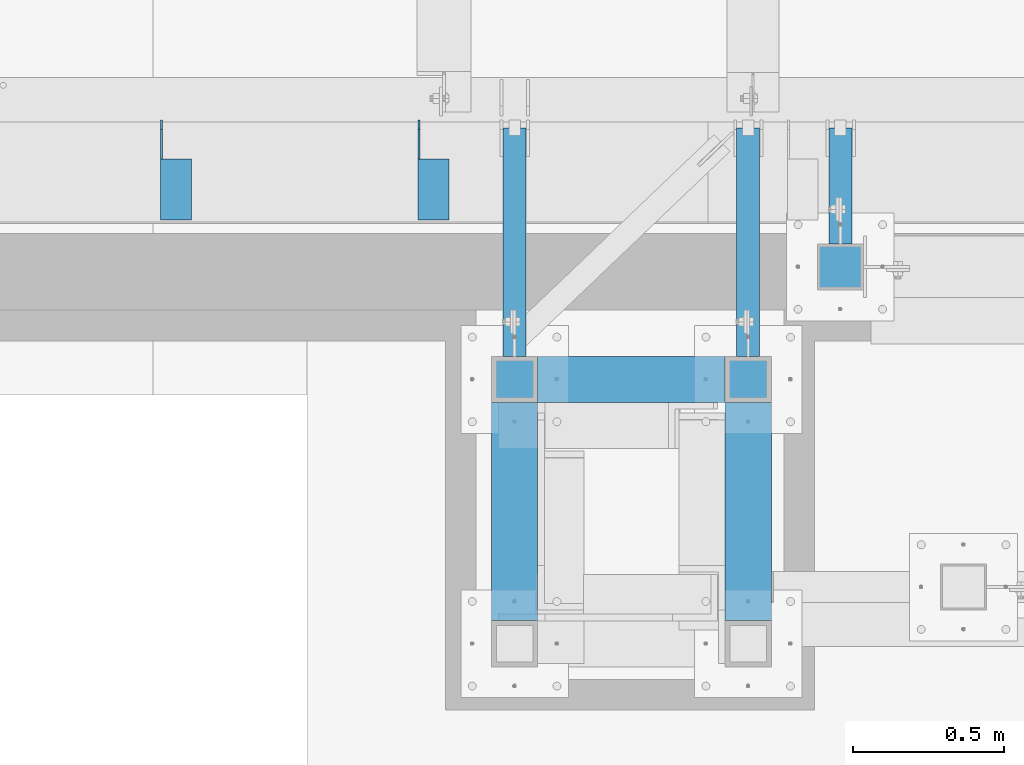
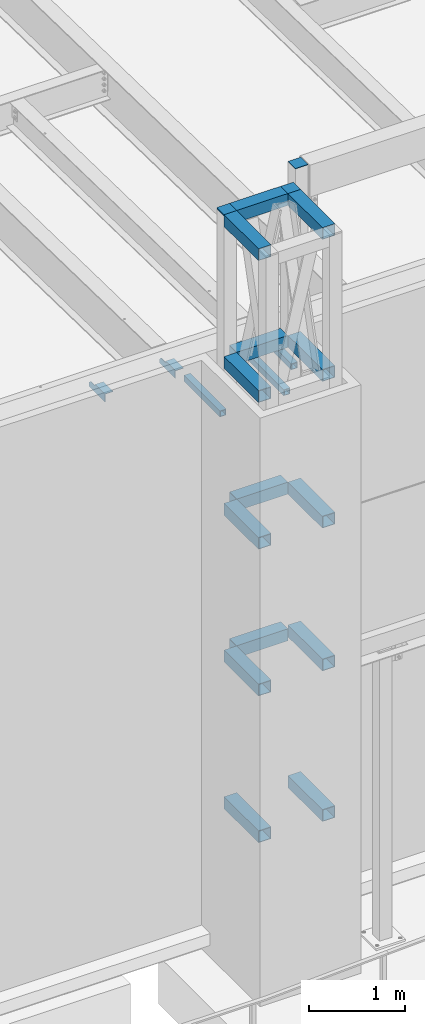
# One storey, part 1180 of 1763: 22 beams, 6 elements without a shape of their own.
"""IFC2X3 building model written with IfcOpenShell, lengths in millimetres."""

from ifc_helpers import new_model, si_unit, frame, origin_with_axes, place, context, subcontext, project, spatial, faceted_brep, material, type_object, element, aggregate, save


model = new_model("IFC2X3")

# Units and contexts
model_context = context("Model", 3, precision=1e-05, world=origin_with_axes())
body_context = subcontext(model_context, "Body", "Model", "MODEL_VIEW")
ifc_project = project(units=[si_unit("LENGTHUNIT", "METRE", prefix="MILLI"), si_unit("AREAUNIT", "SQUARE_METRE"), si_unit("VOLUMEUNIT", "CUBIC_METRE"), si_unit("MASSUNIT", "GRAM", prefix="KILO"), si_unit("TIMEUNIT", "SECOND"), si_unit("PLANEANGLEUNIT", "RADIAN"), si_unit("SOLIDANGLEUNIT", "STERADIAN"), si_unit("THERMODYNAMICTEMPERATUREUNIT", "DEGREE_CELSIUS"), si_unit("LUMINOUSINTENSITYUNIT", "LUMEN")], contexts=[model_context])

# Site, building, storey
site_placement = place(None, origin_with_axes())
site = spatial("IfcSite", under=ifc_project, at=site_placement, CompositionType="ELEMENT")
building_placement = place(site_placement, origin_with_axes())
building = spatial("IfcBuilding", under=site, at=building_placement, Name="Undefined", CompositionType="ELEMENT")
storey_placement = place(building_placement, origin_with_axes())
storey = spatial("IfcBuildingStorey", under=building, at=storey_placement, Name="Undefined", CompositionType="ELEMENT", Elevation=0.0)

# Assembly, beams
assembly_1_placement = place(storey_placement, origin_with_axes())
assembly_1 = element("IfcElementAssembly", 1, at=assembly_1_placement, inside=storey, Name="BEAM", AssemblyPlace="NOTDEFINED", PredefinedType="RIGID_FRAME")
ifc_material_1 = material(Name="STEEL/A36")
beam_type_1 = type_object("IfcBeamType", Name="L4X4X1/4", PredefinedType="NOTDEFINED")
beam_1_placement = place(assembly_1_placement, frame((-70345.6055562792, -13723.1435701429, 12153.8999999999), z_axis=(0.0, 0.0, -1.0), x_axis=(0.0, -1.0, 0.0)))
beam_1 = element("IfcBeam", 2, at=beam_1_placement, type_object=beam_type_1, material=ifc_material_1, Name="BRACE", ObjectType="L4X4X1/4", context=body_context, shape_type="Brep", body=[
    faceted_brep([(127.793748474227, 44.4499999999971, -31.7500007627295), (127.793748474227, 50.8000000000029, -31.7500007627295), (127.793748474225, 50.8000000000029, -50.7999999999993), (127.793748474225, -50.8000000000029, -50.7999999999993), (127.793748474225, -50.8000000000029, -44.4500000000007), (127.793748474225, 44.4499999999971, -44.4500000000007), (31.7499999999673, 44.4499999999971, -31.7500001906901), (31.7499999999673, 50.8000000000029, -31.7500007627295), (-1.81898940354586e-10, 44.4500000000371, 50.7999999999374), (-1.96450855582952e-10, 50.8000000000393, 50.7999999999374), (0.0, 50.8000000000029, -1.90690116141923e-07), (0.0, 44.4499999999971, -1.90690116141923e-07), (329.406260681253, 44.4499999999971, 50.7999999999993), (329.406260681253, 50.8000000000029, 50.7999999999993), (329.406260681253, 44.4499999999971, -44.4500000000007), (329.406260681253, -50.8000000000029, -44.4500000000007), (329.406260681253, -50.8000000000029, -50.7999999999993), (329.406260681253, 50.8000000000029, -50.7999999999993)], [[[0, 1, 2, 3, 4, 5]], [[1, 0, 6, 7]], [[8, 9, 10, 11]], [[9, 8, 12, 13]], [[12, 14, 15, 16, 17, 13]], [[15, 14, 5, 4]], [[16, 15, 4, 3]], [[17, 16, 3, 2]], [[9, 13, 17, 2, 1, 7, 10]], [[6, 11, 10, 7]], [[0, 5, 14, 12, 8, 11, 6]]]),
])
beam_2_placement = place(assembly_1_placement, frame((-71196.5055562792, -13723.1435701429, 12153.8999999998), z_axis=(0.0, 0.0, -1.0), x_axis=(0.0, -1.0, 0.0)))
beam_2 = element("IfcBeam", 3, at=beam_2_placement, type_object=beam_type_1, material=ifc_material_1, Name="BRACE", ObjectType="L4X4X1/4", context=body_context, shape_type="Brep", body=[
    faceted_brep([(127.793748474227, 44.4499999999971, -31.7500007627295), (127.793748474227, 50.8000000000029, -31.7500007627295), (127.793748474225, 50.8000000000029, -50.7999999999993), (127.793748474225, -50.8000000000029, -50.7999999999993), (127.793748474225, -50.8000000000029, -44.4500000000007), (127.793748474225, 44.4499999999971, -44.4500000000007), (31.7499999999673, 44.4499999999971, -31.7500001906901), (31.7499999999673, 50.8000000000029, -31.7500007627295), (-1.81898940354586e-10, 44.4500000000371, 50.7999999999374), (-1.96450855582952e-10, 50.8000000000393, 50.7999999999374), (0.0, 50.8000000000029, -1.90690116141923e-07), (0.0, 44.4499999999971, -1.90690116141923e-07), (329.406260681253, 44.4499999999971, 50.7999999999993), (329.406260681253, 50.8000000000029, 50.7999999999993), (329.406260681253, 44.4499999999971, -44.4500000000007), (329.406260681253, -50.8000000000029, -44.4500000000007), (329.406260681253, -50.8000000000029, -50.7999999999993), (329.406260681253, 50.8000000000029, -50.7999999999993)], [[[0, 1, 2, 3, 4, 5]], [[1, 0, 6, 7]], [[8, 9, 10, 11]], [[9, 8, 12, 13]], [[12, 14, 15, 16, 17, 13]], [[15, 14, 5, 4]], [[16, 15, 4, 3]], [[17, 16, 3, 2]], [[9, 13, 17, 2, 1, 7, 10]], [[6, 11, 10, 7]], [[0, 5, 14, 12, 8, 11, 6]]]),
])
aggregate(assembly_1, [beam_1, beam_2])

# Assembly, beam
assembly_2_placement = place(storey_placement, origin_with_axes())
assembly_2 = element("IfcElementAssembly", 4, at=assembly_2_placement, inside=storey, Name="BEAM", AssemblyPlace="NOTDEFINED", PredefinedType="RIGID_FRAME")
ifc_material_2 = material()
beam_type_2 = type_object("IfcBeamType", Name="HSS3X3X1/4", PredefinedType="NOTDEFINED")
beam_3_placement = place(assembly_2_placement, frame((-69002.1577158888, -14131.9264769908, 11825.2875), z_axis=(0.0, 0.0, 1.0), x_axis=(0.0, 1.0, 0.0)))
beam_3 = element("IfcBeam", 5, at=beam_3_placement, type_object=beam_type_2, material=ifc_material_2, Name="BEAM", ObjectType="HSS3X3X1/4", context=body_context, shape_type="Brep", body=[
    faceted_brep([(0.0, 31.75, -31.75), (0.0, -31.75, -31.75), (383.382908373733, -31.75, -31.75), (383.382908373733, 31.75, -31.75), (0.0, -31.75, 31.75), (383.382908373733, -31.75, 31.75), (0.0, 31.75, 31.75), (383.382908373733, 31.75, 31.75), (0.0, 38.0999999999985, -38.1000000000004), (0.0, 38.0999999999985, 38.1000000000004), (383.382908373733, 38.0999999999985, 38.1000000000004), (383.382908373733, 38.0999999999985, -38.1000000000004), (0.0, -38.0999999999985, 38.1000000000004), (383.382908373733, -38.0999999999985, 38.1000000000004), (0.0, -38.0999999999985, -38.1000000000004), (383.382908373733, -38.0999999999985, -38.1000000000004)], [[[0, 1, 2, 3]], [[1, 4, 5, 2]], [[4, 6, 7, 5]], [[6, 0, 3, 7]], [[8, 9, 10, 11]], [[9, 12, 13, 10]], [[12, 14, 15, 13]], [[14, 8, 11, 15]], [[13, 15, 11, 10], [5, 7, 3, 2]], [[14, 12, 9, 8], [6, 4, 1, 0]]]),
])
aggregate(assembly_2, [beam_3])

assembly_3_placement = place(storey_placement, origin_with_axes())
assembly_3 = element("IfcElementAssembly", 6, at=assembly_3_placement, inside=storey, Name="BEAM", AssemblyPlace="NOTDEFINED", PredefinedType="RIGID_FRAME")
beam_4_placement = place(assembly_3_placement, frame((-69306.51188459, -14503.3992675181, 11825.2875), z_axis=(0.0, 0.0, 1.0), x_axis=(0.0, 1.0, 0.0)))
beam_4 = element("IfcBeam", 7, at=beam_4_placement, type_object=beam_type_2, material=ifc_material_2, Name="BEAM", ObjectType="HSS3X3X1/4", context=body_context, shape_type="Brep", body=[
    faceted_brep([(0.0, 31.75, -31.75), (0.0, -31.75, -31.75), (754.855698901074, -31.75, -31.75), (754.855698901074, 31.75, -31.75), (0.0, -31.75, 31.75), (754.855698901074, -31.75, 31.75), (0.0, 31.75, 31.75), (754.855698901074, 31.75, 31.75), (0.0, 38.0999999999985, -38.1000000000004), (0.0, 38.0999999999985, 38.1000000000004), (754.855698901074, 38.1000000000058, 38.1000000000004), (754.855698901074, 38.1000000000058, -38.1000000000004), (0.0, -38.0999999999985, 38.1000000000004), (754.855698901074, -38.1000000000058, 38.1000000000004), (0.0, -38.0999999999985, -38.1000000000004), (754.855698901074, -38.1000000000058, -38.1000000000004)], [[[0, 1, 2, 3]], [[1, 4, 5, 2]], [[4, 6, 7, 5]], [[6, 0, 3, 7]], [[8, 9, 10, 11]], [[9, 12, 13, 10]], [[12, 14, 15, 13]], [[14, 8, 11, 15]], [[13, 15, 11, 10], [5, 7, 3, 2]], [[14, 12, 9, 8], [6, 4, 1, 0]]]),
])
aggregate(assembly_3, [beam_4])

assembly_4_placement = place(storey_placement, origin_with_axes())
assembly_4 = element("IfcElementAssembly", 8, at=assembly_4_placement, inside=storey, Name="BEAM", AssemblyPlace="NOTDEFINED", PredefinedType="RIGID_FRAME")
beam_5_placement = place(assembly_4_placement, frame((-70078.03688459, -14503.3992675181, 11825.2875), z_axis=(0.0, 0.0, 1.0), x_axis=(0.0, 1.0, 0.0)))
beam_5 = element("IfcBeam", 9, at=beam_5_placement, type_object=beam_type_2, material=ifc_material_2, Name="BEAM", ObjectType="HSS3X3X1/4", context=body_context, shape_type="Brep", body=[
    faceted_brep([(0.0, 31.75, -31.75), (0.0, -31.75, -31.75), (754.855698901074, -31.75, -31.75), (754.855698901074, 31.75, -31.75), (0.0, -31.75, 31.75), (754.855698901074, -31.75, 31.75), (0.0, 31.75, 31.75), (754.855698901074, 31.75, 31.75), (0.0, 38.0999999999985, -38.1000000000004), (0.0, 38.0999999999985, 38.1000000000004), (754.855698901074, 38.1000000000058, 38.1000000000004), (754.855698901074, 38.1000000000058, -38.1000000000004), (0.0, -38.0999999999985, 38.1000000000004), (754.855698901074, -38.1000000000058, 38.1000000000004), (0.0, -38.0999999999985, -38.1000000000004), (754.855698901074, -38.1000000000058, -38.1000000000004)], [[[0, 1, 2, 3]], [[1, 4, 5, 2]], [[4, 6, 7, 5]], [[6, 0, 3, 7]], [[8, 9, 10, 11]], [[9, 12, 13, 10]], [[12, 14, 15, 13]], [[14, 8, 11, 15]], [[13, 15, 11, 10], [5, 7, 3, 2]], [[14, 12, 9, 8], [6, 4, 1, 0]]]),
])
aggregate(assembly_4, [beam_5])

# Assembly, beams
assembly_5_placement = place(storey_placement, origin_with_axes())
assembly_5 = element("IfcElementAssembly", 10, at=assembly_5_placement, inside=storey, Name="FRAME", AssemblyPlace="NOTDEFINED", PredefinedType="RIGID_FRAME")
beam_type_3 = type_object("IfcBeamType", PredefinedType="NOTDEFINED")
beam_6_placement = place(assembly_5_placement, frame((-70078.03688459, -14655.7992675181, 14468.475), z_axis=(1.0, 0.0, 0.0), x_axis=(0.0, 1.0, 0.0)))
beam_6 = element("IfcBeam", 11, at=beam_6_placement, type_object=beam_type_3, material=ifc_material_1, Name="PLATE", context=body_context, shape_type="Brep", body=[
    faceted_brep([(0.0, 9.52499999999964, -76.1999999999971), (0.0, 9.52499999999964, 76.1999999999971), (152.400000000001, 9.52499999999964, 76.1999999999971), (152.400000000001, 9.52499999999964, -76.1999999999971), (0.0, -9.52499999999964, 76.1999999999971), (152.400000000001, -9.52499999999964, 76.1999999999971), (0.0, -9.52499999999964, -76.1999999999971), (152.400000000001, -9.52499999999964, -76.1999999999971)], [[[0, 1, 2, 3]], [[1, 4, 5, 2]], [[4, 6, 7, 5]], [[6, 0, 3, 7]], [[5, 7, 3, 2]], [[6, 4, 1, 0]]]),
])
beam_7_placement = place(assembly_5_placement, frame((-69306.5116892775, -14655.7992675181, 14468.475), z_axis=(1.0, 0.0, 0.0), x_axis=(0.0, 1.0, 0.0)))
beam_7 = element("IfcBeam", 12, at=beam_7_placement, type_object=beam_type_3, material=ifc_material_1, Name="PLATE", context=body_context, shape_type="Brep", body=[
    faceted_brep([(0.0, 9.52499999999964, -76.1999999999971), (0.0, 9.52499999999964, 76.1999999999971), (152.400000000001, 9.52499999999964, 76.1999999999971), (152.400000000001, 9.52499999999964, -76.1999999999971), (0.0, -9.52499999999964, 76.1999999999971), (152.400000000001, -9.52499999999964, 76.1999999999971), (0.0, -9.52499999999964, -76.1999999999971), (152.400000000001, -9.52499999999964, -76.1999999999971)], [[[0, 1, 2, 3]], [[1, 4, 5, 2]], [[4, 6, 7, 5]], [[6, 0, 3, 7]], [[5, 7, 3, 2]], [[6, 4, 1, 0]]]),
])
beam_type_4 = type_object("IfcBeamType", Name="HSS6X6X1/4", PredefinedType="NOTDEFINED")
beam_8_placement = place(assembly_5_placement, frame((-69306.5116892775, -15452.7242675181, 6966.74375), z_axis=(0.0, 0.0, 1.0), x_axis=(0.0, 1.0, 0.0)))
beam_8 = element("IfcBeam", 13, at=beam_8_placement, type_object=beam_type_4, material=ifc_material_2, Name="BEAM", ObjectType="HSS6X6X1/4", context=body_context, shape_type="Brep", body=[
    faceted_brep([(76.2000000000007, 69.8500000000058, -69.8500000000004), (76.2000000000007, -69.8500000000058, -69.8500000000004), (796.924999999999, -69.8500000000058, -69.8500000000004), (796.924999999999, 69.8500000000058, -69.8500000000004), (76.2000000000007, -69.8500000000058, 69.8500000000004), (796.924999999999, -69.8500000000058, 69.8500000000004), (76.2000000000007, 69.8500000000058, 69.8500000000004), (796.924999999999, 69.8500000000058, 69.8500000000004), (76.1999511718459, 76.2000000000007, -76.2000000000007), (76.1999511718459, 76.2000000000007, 76.2000000000007), (796.924999999999, 76.1999999999971, 76.1999999999998), (796.924999999999, 76.1999999999971, -76.1999999999998), (76.1999511718459, -76.2000000000007, 76.2000000000007), (796.924999999999, -76.1999999999971, 76.1999999999998), (76.1999511718459, -76.2000000000007, -76.2000000000007), (796.924999999999, -76.1999999999971, -76.1999999999998)], [[[0, 1, 2, 3]], [[1, 4, 5, 2]], [[4, 6, 7, 5]], [[6, 0, 3, 7]], [[8, 9, 10, 11]], [[9, 12, 13, 10]], [[12, 14, 15, 13]], [[14, 8, 11, 15]], [[13, 15, 11, 10], [5, 7, 3, 2]], [[14, 12, 9, 8], [6, 4, 1, 0]]]),
])
beam_9_placement = place(assembly_5_placement, frame((-70078.0366892775, -15452.7242675181, 6966.74375), z_axis=(0.0, 0.0, 1.0), x_axis=(0.0, 1.0, 0.0)))
beam_9 = element("IfcBeam", 14, at=beam_9_placement, type_object=beam_type_4, material=ifc_material_2, Name="BEAM", ObjectType="HSS6X6X1/4", context=body_context, shape_type="Brep", body=[
    faceted_brep([(76.2000000000007, 69.8500000000058, -69.8500000000004), (76.2000000000007, -69.8500000000058, -69.8500000000004), (796.924999999999, -69.8500000000058, -69.8500000000004), (796.924999999999, 69.8500000000058, -69.8500000000004), (76.2000000000007, -69.8500000000058, 69.8500000000004), (796.924999999999, -69.8500000000058, 69.8500000000004), (76.2000000000007, 69.8500000000058, 69.8500000000004), (796.924999999999, 69.8500000000058, 69.8500000000004), (76.1999511718459, 76.2000000000007, -76.2000000000007), (76.1999511718459, 76.2000000000007, 76.2000000000007), (796.924999999999, 76.1999999999971, 76.1999999999998), (796.924999999999, 76.1999999999971, -76.1999999999998), (76.1999511718459, -76.2000000000007, 76.2000000000007), (796.924999999999, -76.1999999999971, 76.1999999999998), (76.1999511718459, -76.2000000000007, -76.2000000000007), (796.924999999999, -76.1999999999971, -76.1999999999998)], [[[0, 1, 2, 3]], [[1, 4, 5, 2]], [[4, 6, 7, 5]], [[6, 0, 3, 7]], [[8, 9, 10, 11]], [[9, 12, 13, 10]], [[12, 14, 15, 13]], [[14, 8, 11, 15]], [[13, 15, 11, 10], [5, 7, 3, 2]], [[14, 12, 9, 8], [6, 4, 1, 0]]]),
])
beam_10_placement = place(assembly_5_placement, frame((-70078.0366892775, -14579.5992675181, 8840.7875), z_axis=(0.0, 0.0, 1.0), x_axis=(1.0, 0.0, 0.0)))
beam_10 = element("IfcBeam", 15, at=beam_10_placement, type_object=beam_type_4, material=ifc_material_2, Name="BEAM", ObjectType="HSS6X6X1/4", context=body_context, shape_type="Brep", body=[
    faceted_brep([(76.1998046874942, 69.8500000000004, -69.8500000000004), (76.1998046874942, -69.8500000000004, -69.8500000000004), (695.325000000012, -69.8500000000004, -69.8500000000004), (695.325000000012, 69.8500000000004, -69.8500000000004), (76.1998046874942, -69.8500000000004, 69.8500000000004), (695.325000000012, -69.8500000000004, 69.8500000000004), (76.1998046874942, 69.8500000000004, 69.8500000000004), (695.325000000012, 69.8500000000004, 69.8500000000004), (76.1998535156017, 76.2000000000007, -76.1999999999998), (76.1998535156017, 76.2000000000007, 76.1999999999998), (695.325048828119, 76.2000000000007, 76.1999999999998), (695.325048828119, 76.2000000000007, -76.1999999999998), (76.1998535156017, -76.2000000000007, 76.1999999999998), (695.325048828119, -76.2000000000007, 76.1999999999998), (76.1998535156017, -76.2000000000007, -76.1999999999998), (695.325048828119, -76.2000000000007, -76.1999999999998)], [[[0, 1, 2, 3]], [[1, 4, 5, 2]], [[4, 6, 7, 5]], [[6, 0, 3, 7]], [[8, 9, 10, 11]], [[9, 12, 13, 10]], [[12, 14, 15, 13]], [[14, 8, 11, 15]], [[13, 15, 11, 10], [5, 7, 3, 2]], [[14, 12, 9, 8], [6, 4, 1, 0]]]),
])
beam_11_placement = place(assembly_5_placement, frame((-70078.0366892775, -15452.7242675181, 8840.7875), z_axis=(0.0, 0.0, 1.0), x_axis=(0.0, 1.0, 0.0)))
beam_11 = element("IfcBeam", 16, at=beam_11_placement, type_object=beam_type_4, material=ifc_material_2, Name="BEAM", ObjectType="HSS6X6X1/4", context=body_context, shape_type="Brep", body=[
    faceted_brep([(76.2000000000007, 69.8500000000058, -69.8500000000004), (76.2000000000007, -69.8500000000058, -69.8500000000004), (796.924999999999, -69.8500000000058, -69.8500000000004), (796.924999999999, 69.8500000000058, -69.8500000000004), (76.2000000000007, -69.8500000000058, 69.8500000000004), (796.924999999999, -69.8500000000058, 69.8500000000004), (76.2000000000007, 69.8500000000058, 69.8500000000004), (796.924999999999, 69.8500000000058, 69.8500000000004), (76.1999511718459, 76.2000000000007, -76.2000000000007), (76.1999511718459, 76.2000000000007, 76.2000000000007), (796.924999999999, 76.1999999999971, 76.1999999999998), (796.924999999999, 76.1999999999971, -76.1999999999998), (76.1999511718459, -76.2000000000007, 76.2000000000007), (796.924999999999, -76.1999999999971, 76.1999999999998), (76.1999511718459, -76.2000000000007, -76.2000000000007), (796.924999999999, -76.1999999999971, -76.1999999999998)], [[[0, 1, 2, 3]], [[1, 4, 5, 2]], [[4, 6, 7, 5]], [[6, 0, 3, 7]], [[8, 9, 10, 11]], [[9, 12, 13, 10]], [[12, 14, 15, 13]], [[14, 8, 11, 15]], [[13, 15, 11, 10], [5, 7, 3, 2]], [[14, 12, 9, 8], [6, 4, 1, 0]]]),
])
beam_12_placement = place(assembly_5_placement, frame((-70078.0366892775, -14579.5992675181, 10714.83125), z_axis=(0.0, 0.0, 1.0), x_axis=(1.0, 0.0, 0.0)))
beam_12 = element("IfcBeam", 17, at=beam_12_placement, type_object=beam_type_4, material=ifc_material_2, Name="BEAM", ObjectType="HSS6X6X1/4", context=body_context, shape_type="Brep", body=[
    faceted_brep([(76.1998046874942, 69.8500000000004, -69.8500000000004), (76.1998046874942, -69.8500000000004, -69.8500000000004), (695.325000000012, -69.8500000000004, -69.8500000000004), (695.325000000012, 69.8500000000004, -69.8500000000004), (76.1998046874942, -69.8500000000004, 69.8500000000004), (695.325000000012, -69.8500000000004, 69.8500000000004), (76.1998046874942, 69.8500000000004, 69.8500000000004), (695.325000000012, 69.8500000000004, 69.8500000000004), (76.1998535156017, 76.2000000000007, -76.1999999999998), (76.1998535156017, 76.2000000000007, 76.1999999999998), (695.325048828119, 76.2000000000007, 76.1999999999998), (695.325048828119, 76.2000000000007, -76.1999999999998), (76.1998535156017, -76.2000000000007, 76.1999999999998), (695.325048828119, -76.2000000000007, 76.1999999999998), (76.1998535156017, -76.2000000000007, -76.1999999999998), (695.325048828119, -76.2000000000007, -76.1999999999998)], [[[0, 1, 2, 3]], [[1, 4, 5, 2]], [[4, 6, 7, 5]], [[6, 0, 3, 7]], [[8, 9, 10, 11]], [[9, 12, 13, 10]], [[12, 14, 15, 13]], [[14, 8, 11, 15]], [[13, 15, 11, 10], [5, 7, 3, 2]], [[14, 12, 9, 8], [6, 4, 1, 0]]]),
])
beam_13_placement = place(assembly_5_placement, frame((-69306.5116892775, -15452.7242675181, 10714.83125), z_axis=(0.0, 0.0, 1.0), x_axis=(0.0, 1.0, 0.0)))
beam_13 = element("IfcBeam", 18, at=beam_13_placement, type_object=beam_type_4, material=ifc_material_2, Name="BEAM", ObjectType="HSS6X6X1/4", context=body_context, shape_type="Brep", body=[
    faceted_brep([(76.2000000000007, 69.8500000000058, -69.8500000000004), (76.2000000000007, -69.8500000000058, -69.8500000000004), (796.924999999999, -69.8500000000058, -69.8500000000004), (796.924999999999, 69.8500000000058, -69.8500000000004), (76.2000000000007, -69.8500000000058, 69.8500000000004), (796.924999999999, -69.8500000000058, 69.8500000000004), (76.2000000000007, 69.8500000000058, 69.8500000000004), (796.924999999999, 69.8500000000058, 69.8500000000004), (76.1999511718459, 76.2000000000007, -76.2000000000007), (76.1999511718459, 76.2000000000007, 76.2000000000007), (796.924999999999, 76.1999999999971, 76.1999999999998), (796.924999999999, 76.1999999999971, -76.1999999999998), (76.1999511718459, -76.2000000000007, 76.2000000000007), (796.924999999999, -76.1999999999971, 76.1999999999998), (76.1999511718459, -76.2000000000007, -76.2000000000007), (796.924999999999, -76.1999999999971, -76.1999999999998)], [[[0, 1, 2, 3]], [[1, 4, 5, 2]], [[4, 6, 7, 5]], [[6, 0, 3, 7]], [[8, 9, 10, 11]], [[9, 12, 13, 10]], [[12, 14, 15, 13]], [[14, 8, 11, 15]], [[13, 15, 11, 10], [5, 7, 3, 2]], [[14, 12, 9, 8], [6, 4, 1, 0]]]),
])
beam_14_placement = place(assembly_5_placement, frame((-70078.0366892775, -15452.7242675181, 10714.83125), z_axis=(0.0, 0.0, 1.0), x_axis=(0.0, 1.0, 0.0)))
beam_14 = element("IfcBeam", 19, at=beam_14_placement, type_object=beam_type_4, material=ifc_material_2, Name="BEAM", ObjectType="HSS6X6X1/4", context=body_context, shape_type="Brep", body=[
    faceted_brep([(76.2000000000007, 69.8500000000058, -69.8500000000004), (76.2000000000007, -69.8500000000058, -69.8500000000004), (796.924999999999, -69.8500000000058, -69.8500000000004), (796.924999999999, 69.8500000000058, -69.8500000000004), (76.2000000000007, -69.8500000000058, 69.8500000000004), (796.924999999999, -69.8500000000058, 69.8500000000004), (76.2000000000007, 69.8500000000058, 69.8500000000004), (796.924999999999, 69.8500000000058, 69.8500000000004), (76.1999511718459, 76.2000000000007, -76.2000000000007), (76.1999511718459, 76.2000000000007, 76.2000000000007), (796.924999999999, 76.1999999999971, 76.1999999999998), (796.924999999999, 76.1999999999971, -76.1999999999998), (76.1999511718459, -76.2000000000007, 76.2000000000007), (796.924999999999, -76.1999999999971, 76.1999999999998), (76.1999511718459, -76.2000000000007, -76.2000000000007), (796.924999999999, -76.1999999999971, -76.1999999999998)], [[[0, 1, 2, 3]], [[1, 4, 5, 2]], [[4, 6, 7, 5]], [[6, 0, 3, 7]], [[8, 9, 10, 11]], [[9, 12, 13, 10]], [[12, 14, 15, 13]], [[14, 8, 11, 15]], [[13, 15, 11, 10], [5, 7, 3, 2]], [[14, 12, 9, 8], [6, 4, 1, 0]]]),
])
beam_15_placement = place(assembly_5_placement, frame((-69306.51188459, -15452.7242675181, 8890.0), z_axis=(0.0, 0.0, 1.0), x_axis=(0.0, 1.0, 0.0)))
beam_15 = element("IfcBeam", 20, at=beam_15_placement, type_object=beam_type_4, material=ifc_material_2, Name="BEAM", ObjectType="HSS6X6X1/4", context=body_context, shape_type="Brep", body=[
    faceted_brep([(76.2000000000007, 69.8500000000058, -69.8500000000004), (76.2000000000007, -69.8500000000058, -69.8500000000004), (796.924999999999, -69.8500000000058, -69.8500000000004), (796.924999999999, 69.8500000000058, -69.8500000000004), (76.2000000000007, -69.8500000000058, 69.8500000000004), (796.924999999999, -69.8500000000058, 69.8500000000004), (76.2000000000007, 69.8500000000058, 69.8500000000004), (796.924999999999, 69.8500000000058, 69.8500000000004), (76.1999511718459, 76.2000000000007, -76.2000000000007), (76.1999511718459, 76.2000000000007, 76.2000000000007), (796.924999999999, 76.1999999999971, 76.1999999999998), (796.924999999999, 76.1999999999971, -76.1999999999998), (76.1999511718459, -76.2000000000007, 76.2000000000007), (796.924999999999, -76.1999999999971, 76.1999999999998), (76.1999511718459, -76.2000000000007, -76.2000000000007), (796.924999999999, -76.1999999999971, -76.1999999999998)], [[[0, 1, 2, 3]], [[1, 4, 5, 2]], [[4, 6, 7, 5]], [[6, 0, 3, 7]], [[8, 9, 10, 11]], [[9, 12, 13, 10]], [[12, 14, 15, 13]], [[14, 8, 11, 15]], [[13, 15, 11, 10], [5, 7, 3, 2]], [[14, 12, 9, 8], [6, 4, 1, 0]]]),
])
beam_16_placement = place(assembly_5_placement, frame((-70078.03688459, -14579.5992675181, 14401.8), z_axis=(0.0, 0.0, 1.0), x_axis=(1.0, 0.0, 0.0)))
beam_16 = element("IfcBeam", 21, at=beam_16_placement, type_object=beam_type_4, material=ifc_material_2, Name="BEAM", ObjectType="HSS6X6X1/4", context=body_context, shape_type="Brep", body=[
    faceted_brep([(76.2000000000007, 69.8500000000058, -69.8500000000004), (76.2000000000007, -69.8500000000058, -69.8500000000004), (695.3251953125, -69.8500000000004, -69.8500000000004), (695.3251953125, 69.8500000000004, -69.8500000000004), (76.2000000000007, -69.8500000000058, 69.8500000000004), (695.3251953125, -69.8500000000004, 69.8500000000004), (76.2000000000007, 69.8500000000058, 69.8500000000004), (695.3251953125, 69.8500000000004, 69.8500000000004), (76.1999511718459, 76.2000000000007, -76.2000000000007), (76.1999511718459, 76.2000000000007, 76.2000000000007), (695.325146484363, 76.2000000000007, 76.2000000000007), (695.325146484363, 76.2000000000007, -76.2000000000007), (76.1999511718459, -76.2000000000007, 76.2000000000007), (695.325146484363, -76.2000000000007, 76.2000000000007), (76.1999511718459, -76.2000000000007, -76.2000000000007), (695.325146484363, -76.2000000000007, -76.2000000000007)], [[[0, 1, 2, 3]], [[1, 4, 5, 2]], [[4, 6, 7, 5]], [[6, 0, 3, 7]], [[8, 9, 10, 11]], [[9, 12, 13, 10]], [[12, 14, 15, 13]], [[14, 8, 11, 15]], [[13, 15, 11, 10], [5, 7, 3, 2]], [[14, 12, 9, 8], [6, 4, 1, 0]]]),
])
beam_17_placement = place(assembly_5_placement, frame((-69306.5116892775, -15452.7242675181, 14401.8), z_axis=(0.0, 0.0, 1.0), x_axis=(0.0, 1.0, 0.0)))
beam_17 = element("IfcBeam", 22, at=beam_17_placement, type_object=beam_type_4, material=ifc_material_2, Name="BEAM", ObjectType="HSS6X6X1/4", context=body_context, shape_type="Brep", body=[
    faceted_brep([(76.2000000000007, 69.8500000000058, -69.8500000000004), (76.2000000000007, -69.8500000000058, -69.8500000000004), (796.924999999999, -69.8500000000058, -69.8500000000004), (796.924999999999, 69.8500000000058, -69.8500000000004), (76.2000000000007, -69.8500000000058, 69.8500000000004), (796.924999999999, -69.8500000000058, 69.8500000000004), (76.2000000000007, 69.8500000000058, 69.8500000000004), (796.924999999999, 69.8500000000058, 69.8500000000004), (76.1999511718459, 76.2000000000007, -76.2000000000007), (76.1999511718459, 76.2000000000007, 76.2000000000007), (796.924999999999, 76.1999999999971, 76.1999999999998), (796.924999999999, 76.1999999999971, -76.1999999999998), (76.1999511718459, -76.2000000000007, 76.2000000000007), (796.924999999999, -76.1999999999971, 76.1999999999998), (76.1999511718459, -76.2000000000007, -76.2000000000007), (796.924999999999, -76.1999999999971, -76.1999999999998)], [[[0, 1, 2, 3]], [[1, 4, 5, 2]], [[4, 6, 7, 5]], [[6, 0, 3, 7]], [[8, 9, 10, 11]], [[9, 12, 13, 10]], [[12, 14, 15, 13]], [[14, 8, 11, 15]], [[13, 15, 11, 10], [5, 7, 3, 2]], [[14, 12, 9, 8], [6, 4, 1, 0]]]),
])
beam_18_placement = place(assembly_5_placement, frame((-70078.0366892775, -15452.7242675181, 14401.8), z_axis=(0.0, 0.0, 1.0), x_axis=(0.0, 1.0, 0.0)))
beam_18 = element("IfcBeam", 23, at=beam_18_placement, type_object=beam_type_4, material=ifc_material_2, Name="BEAM", ObjectType="HSS6X6X1/4", context=body_context, shape_type="Brep", body=[
    faceted_brep([(76.2000000000007, 69.8500000000058, -69.8500000000004), (76.2000000000007, -69.8500000000058, -69.8500000000004), (796.924999999999, -69.8500000000058, -69.8500000000004), (796.924999999999, 69.8500000000058, -69.8500000000004), (76.2000000000007, -69.8500000000058, 69.8500000000004), (796.924999999999, -69.8500000000058, 69.8500000000004), (76.2000000000007, 69.8500000000058, 69.8500000000004), (796.924999999999, 69.8500000000058, 69.8500000000004), (76.1999511718459, 76.2000000000007, -76.2000000000007), (76.1999511718459, 76.2000000000007, 76.2000000000007), (796.924999999999, 76.1999999999971, 76.1999999999998), (796.924999999999, 76.1999999999971, -76.1999999999998), (76.1999511718459, -76.2000000000007, 76.2000000000007), (796.924999999999, -76.1999999999971, 76.1999999999998), (76.1999511718459, -76.2000000000007, -76.2000000000007), (796.924999999999, -76.1999999999971, -76.1999999999998)], [[[0, 1, 2, 3]], [[1, 4, 5, 2]], [[4, 6, 7, 5]], [[6, 0, 3, 7]], [[8, 9, 10, 11]], [[9, 12, 13, 10]], [[12, 14, 15, 13]], [[14, 8, 11, 15]], [[13, 15, 11, 10], [5, 7, 3, 2]], [[14, 12, 9, 8], [6, 4, 1, 0]]]),
])
beam_19_placement = place(assembly_5_placement, frame((-70078.0366892775, -14579.5992675181, 12588.875), z_axis=(0.0, 0.0, 1.0), x_axis=(1.0, 0.0, 0.0)))
beam_19 = element("IfcBeam", 24, at=beam_19_placement, type_object=beam_type_4, material=ifc_material_2, Name="BEAM", ObjectType="HSS6X6X1/4", context=body_context, shape_type="Brep", body=[
    faceted_brep([(76.1998046874942, 69.8500000000004, -69.8500000000004), (76.1998046874942, -69.8500000000004, -69.8500000000004), (695.325000000012, -69.8500000000004, -69.8500000000004), (695.325000000012, 69.8500000000004, -69.8500000000004), (76.1998046874942, -69.8500000000004, 69.8500000000004), (695.325000000012, -69.8500000000004, 69.8500000000004), (76.1998046874942, 69.8500000000004, 69.8500000000004), (695.325000000012, 69.8500000000004, 69.8500000000004), (76.1998535156017, 76.2000000000007, -76.1999999999998), (76.1998535156017, 76.2000000000007, 76.1999999999998), (695.325048828119, 76.2000000000007, 76.1999999999998), (695.325048828119, 76.2000000000007, -76.1999999999998), (76.1998535156017, -76.2000000000007, 76.1999999999998), (695.325048828119, -76.2000000000007, 76.1999999999998), (76.1998535156017, -76.2000000000007, -76.1999999999998), (695.325048828119, -76.2000000000007, -76.1999999999998)], [[[0, 1, 2, 3]], [[1, 4, 5, 2]], [[4, 6, 7, 5]], [[6, 0, 3, 7]], [[8, 9, 10, 11]], [[9, 12, 13, 10]], [[12, 14, 15, 13]], [[14, 8, 11, 15]], [[13, 15, 11, 10], [5, 7, 3, 2]], [[14, 12, 9, 8], [6, 4, 1, 0]]]),
])
beam_20_placement = place(assembly_5_placement, frame((-69306.5116892775, -15452.7242675181, 12588.875), z_axis=(0.0, 0.0, 1.0), x_axis=(0.0, 1.0, 0.0)))
beam_20 = element("IfcBeam", 25, at=beam_20_placement, type_object=beam_type_4, material=ifc_material_2, Name="BEAM", ObjectType="HSS6X6X1/4", context=body_context, shape_type="Brep", body=[
    faceted_brep([(76.2000000000007, 69.8500000000058, -69.8500000000004), (76.2000000000007, -69.8500000000058, -69.8500000000004), (796.924999999999, -69.8500000000058, -69.8500000000004), (796.924999999999, 69.8500000000058, -69.8500000000004), (76.2000000000007, -69.8500000000058, 69.8500000000004), (796.924999999999, -69.8500000000058, 69.8500000000004), (76.2000000000007, 69.8500000000058, 69.8500000000004), (796.924999999999, 69.8500000000058, 69.8500000000004), (76.1999511718459, 76.2000000000007, -76.2000000000007), (76.1999511718459, 76.2000000000007, 76.2000000000007), (796.924999999999, 76.1999999999971, 76.1999999999998), (796.924999999999, 76.1999999999971, -76.1999999999998), (76.1999511718459, -76.2000000000007, 76.2000000000007), (796.924999999999, -76.1999999999971, 76.1999999999998), (76.1999511718459, -76.2000000000007, -76.2000000000007), (796.924999999999, -76.1999999999971, -76.1999999999998)], [[[0, 1, 2, 3]], [[1, 4, 5, 2]], [[4, 6, 7, 5]], [[6, 0, 3, 7]], [[8, 9, 10, 11]], [[9, 12, 13, 10]], [[12, 14, 15, 13]], [[14, 8, 11, 15]], [[13, 15, 11, 10], [5, 7, 3, 2]], [[14, 12, 9, 8], [6, 4, 1, 0]]]),
])
beam_21_placement = place(assembly_5_placement, frame((-70078.0366892775, -15452.7242675181, 12588.875), z_axis=(0.0, 0.0, 1.0), x_axis=(0.0, 1.0, 0.0)))
beam_21 = element("IfcBeam", 26, at=beam_21_placement, type_object=beam_type_4, material=ifc_material_2, Name="BEAM", ObjectType="HSS6X6X1/4", context=body_context, shape_type="Brep", body=[
    faceted_brep([(76.2000000000007, 69.8500000000058, -69.8500000000004), (76.2000000000007, -69.8500000000058, -69.8500000000004), (796.924999999999, -69.8500000000058, -69.8500000000004), (796.924999999999, 69.8500000000058, -69.8500000000004), (76.2000000000007, -69.8500000000058, 69.8500000000004), (796.924999999999, -69.8500000000058, 69.8500000000004), (76.2000000000007, 69.8500000000058, 69.8500000000004), (796.924999999999, 69.8500000000058, 69.8500000000004), (76.1999511718459, 76.2000000000007, -76.2000000000007), (76.1999511718459, 76.2000000000007, 76.2000000000007), (796.924999999999, 76.1999999999971, 76.1999999999998), (796.924999999999, 76.1999999999971, -76.1999999999998), (76.1999511718459, -76.2000000000007, 76.2000000000007), (796.924999999999, -76.1999999999971, 76.1999999999998), (76.1999511718459, -76.2000000000007, -76.2000000000007), (796.924999999999, -76.1999999999971, -76.1999999999998)], [[[0, 1, 2, 3]], [[1, 4, 5, 2]], [[4, 6, 7, 5]], [[6, 0, 3, 7]], [[8, 9, 10, 11]], [[9, 12, 13, 10]], [[12, 14, 15, 13]], [[14, 8, 11, 15]], [[13, 15, 11, 10], [5, 7, 3, 2]], [[14, 12, 9, 8], [6, 4, 1, 0]]]),
])
aggregate(assembly_5, [beam_8, beam_9, beam_10, beam_11, beam_12, beam_13, beam_14, beam_15, beam_6, beam_7, beam_16, beam_17, beam_18, beam_19, beam_20, beam_21])

# Assembly, beam
assembly_6_placement = place(storey_placement, origin_with_axes())
assembly_6 = element("IfcElementAssembly", 27, at=assembly_6_placement, inside=storey, Name="COLUMN", AssemblyPlace="NOTDEFINED", PredefinedType="RIGID_FRAME")
beam_type_5 = type_object("IfcBeamType", PredefinedType="NOTDEFINED")
beam_22_placement = place(assembly_6_placement, frame((-69002.1577158888, -14284.3264769908, 14462.125), z_axis=(1.0, 0.0, 0.0), x_axis=(0.0, 1.0, 0.0)))
beam_22 = element("IfcBeam", 28, at=beam_22_placement, type_object=beam_type_5, material=ifc_material_1, Name="PLATE", context=body_context, shape_type="Brep", body=[
    faceted_brep([(0.0, 3.17500000001746, -76.2000000000007), (-1.51339918375015e-09, 3.17499999999927, 76.1999969482422), (152.399990844715, 3.17500000000291, 76.2000000000007), (152.399990844715, 3.17500000000291, -76.2000000000007), (-1.51339918375015e-09, -3.17499999999927, 76.1999969482422), (152.399990844715, -3.17500000000291, 76.2000000000007), (0.0, -3.17500000000291, -76.2000000000007), (152.399990844715, -3.17500000000291, -76.2000000000007)], [[[0, 1, 2, 3]], [[1, 4, 5, 2]], [[4, 6, 7, 5]], [[6, 0, 3, 7]], [[5, 7, 3, 2]], [[6, 4, 1, 0]]]),
])
aggregate(assembly_6, [beam_22])

save(model, "model.ifc")
